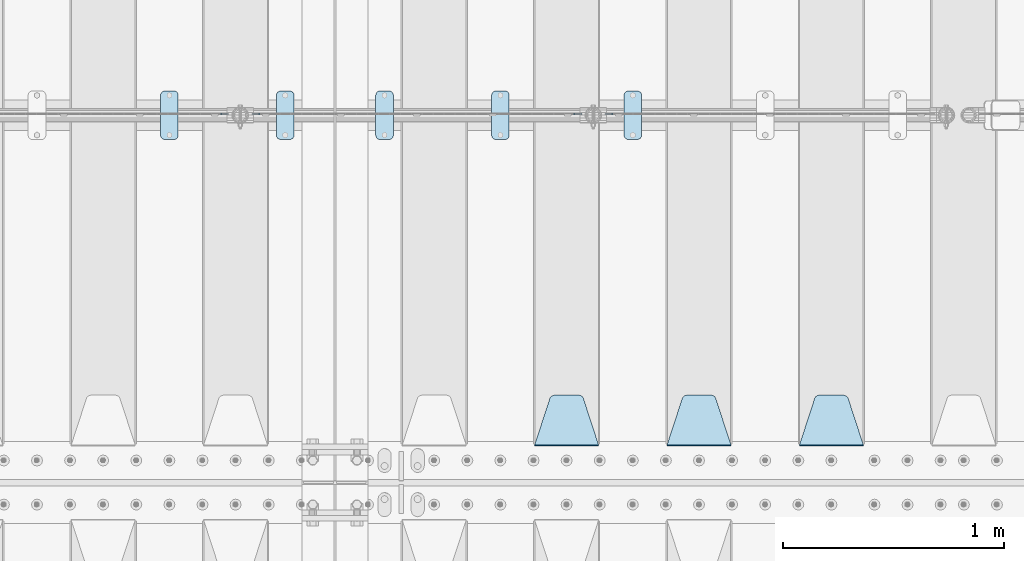
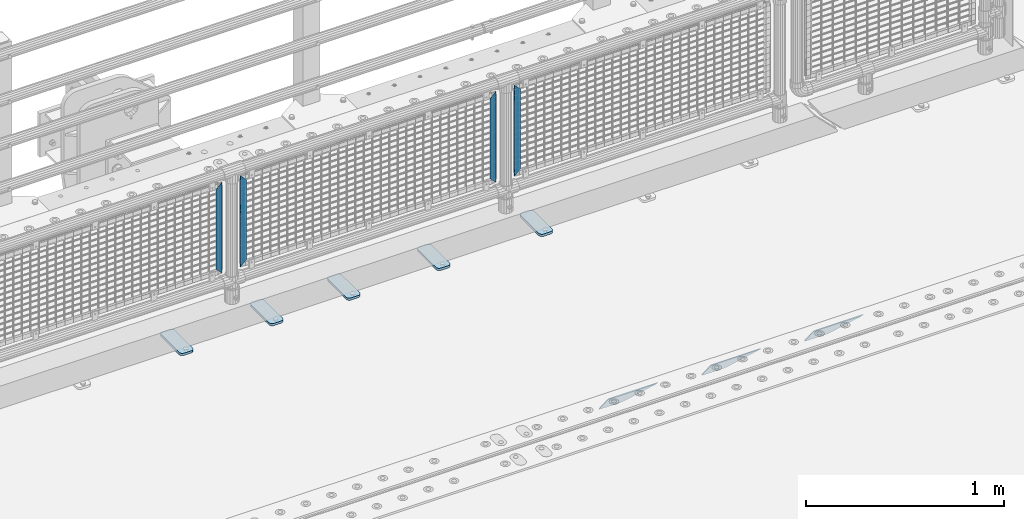
# One storey, part 228 of 257: 12 plates.
"""IFC2X3 building model written with IfcOpenShell, lengths in millimetres."""

from ifc_helpers import new_model, si_unit, frame, origin_with_axes, place, context, subcontext, project, spatial, faceted_brep, material, type_object, element, save


model = new_model("IFC2X3")

# Units and contexts
model_context = context("Model", 3, precision=1e-05, world=origin_with_axes())
body_context = subcontext(model_context, "Body", "Model", "MODEL_VIEW")
ifc_project = project(units=[si_unit("LENGTHUNIT", "METRE", prefix="MILLI"), si_unit("AREAUNIT", "SQUARE_METRE"), si_unit("VOLUMEUNIT", "CUBIC_METRE"), si_unit("MASSUNIT", "GRAM", prefix="KILO"), si_unit("TIMEUNIT", "SECOND"), si_unit("PLANEANGLEUNIT", "RADIAN"), si_unit("SOLIDANGLEUNIT", "STERADIAN"), si_unit("THERMODYNAMICTEMPERATUREUNIT", "DEGREE_CELSIUS"), si_unit("LUMINOUSINTENSITYUNIT", "LUMEN")], contexts=[model_context])

# Site, building, storey
site_placement = place(None, origin_with_axes())
site = spatial("IfcSite", under=ifc_project, at=site_placement, CompositionType="ELEMENT")
building_placement = place(site_placement, origin_with_axes())
building = spatial("IfcBuilding", under=site, at=building_placement, Name="Standard", CompositionType="ELEMENT")
storey_placement = place(building_placement, origin_with_axes())
storey = spatial("IfcBuildingStorey", under=building, at=storey_placement, Name="Undefined", CompositionType="ELEMENT", Elevation=0.0)

# Plates
ifc_material_1 = material(Name="STEEL/S355J2")
plate_type_1 = type_object("IfcPlateType", PredefinedType="NOTDEFINED")
plate_1_placement = place(storey_placement, frame((56010.0, 10774.5, 21.0199999999977), z_axis=(1.0, 0.0, 0.0), x_axis=(0.0, -1.0, 0.0)))
element("IfcPlate", 1, at=plate_1_placement, inside=storey, type_object=plate_type_1, material=ifc_material_1, context=body_context, shape_type="Brep", body=[
    faceted_brep([(0.0, -7.0, 20.0), (0.0, -7.0, 60.0), (0.0, 7.0, 60.0), (0.0, 7.0, 20.0), (0.384294391935327, -7.0, 63.9018064403208), (0.384294391935327, 7.0, 63.9018064403208), (1.52240934977453, -7.0, 67.6536686473046), (1.52240934977453, 7.0, 67.6536686473046), (3.37060775394821, -7.0, 71.1114046603907), (3.37060775394821, 7.0, 71.1114046603907), (5.85786437626848, -7.0, 74.1421356237333), (5.85786437626848, 7.0, 74.1421356237333), (8.88859533960749, -7.0, 76.6293922460536), (8.88859533960749, 7.0, 76.6293922460536), (12.3463313526991, -7.0, 78.4775906502255), (12.3463313526991, 7.0, 78.4775906502255), (16.0981935596774, -7.0, 79.6157056080629), (16.0981935596774, 7.0, 79.6157056080629), (20.0, -7.0, 80.0), (20.0, 7.0, 80.0), (200.0, -7.0, 80.0), (200.0, 7.0, 80.0), (203.901806440323, -7.0, 79.6157056080629), (203.901806440323, 7.0, 79.6157056080629), (207.653668647301, -7.0, 78.4775906502255), (207.653668647301, 7.0, 78.4775906502255), (211.111404660393, -7.0, 76.6293922460536), (211.111404660393, 7.0, 76.6293922460536), (214.142135623732, -7.0, 74.1421356237333), (214.142135623732, 7.0, 74.1421356237333), (216.629392246052, -7.0, 71.1114046603907), (216.629392246052, 7.0, 71.1114046603907), (218.477590650225, -7.0, 67.6536686473046), (218.477590650225, 7.0, 67.6536686473046), (219.615705608065, -7.0, 63.9018064403208), (219.615705608065, 7.0, 63.9018064403208), (220.0, -7.0, 60.0), (220.0, 7.0, 60.0), (220.0, -7.0, 20.0), (220.0, 7.0, 20.0), (219.615705608065, -7.0, 16.0981935596792), (219.615705608065, 7.0, 16.0981935596792), (218.477590650225, -7.0, 12.3463313526954), (218.477590650225, 7.0, 12.3463313526954), (216.629392246052, -7.0, 8.88859533960931), (216.629392246052, 7.0, 8.88859533960931), (214.142135623732, -7.0, 5.85786437626666), (214.142135623732, 7.0, 5.85786437626666), (211.111404660393, -7.0, 3.37060775394639), (211.111404660393, 7.0, 3.37060775394639), (207.653668647301, -7.0, 1.52240934977453), (207.653668647301, 7.0, 1.52240934977453), (203.901806440323, -7.0, 0.384294391937146), (203.901806440323, 7.0, 0.384294391937146), (200.0, -7.0, 0.0), (200.0, 7.0, 0.0), (20.0, -7.0, 0.0), (20.0, 7.0, 0.0), (16.0981935596774, -7.0, 0.384294391937146), (16.0981935596774, 7.0, 0.384294391937146), (12.3463313526991, -7.0, 1.52240934977453), (12.3463313526991, 7.0, 1.52240934977453), (8.88859533960749, -7.0, 3.37060775394639), (8.88859533960749, 7.0, 3.37060775394639), (5.85786437626848, -7.0, 5.85786437626666), (5.85786437626848, 7.0, 5.85786437626666), (3.37060775394821, -7.0, 8.88859533960931), (3.37060775394821, 7.0, 8.88859533960931), (1.52240934977453, -7.0, 12.3463313526954), (1.52240934977453, 7.0, 12.3463313526954), (0.384294391935327, -7.0, 16.0981935596792), (0.384294391935327, 7.0, 16.0981935596792)], [[[0, 1, 2, 3]], [[1, 4, 5, 2]], [[4, 6, 7, 5]], [[6, 8, 9, 7]], [[8, 10, 11, 9]], [[10, 12, 13, 11]], [[12, 14, 15, 13]], [[14, 16, 17, 15]], [[16, 18, 19, 17]], [[18, 20, 21, 19]], [[20, 22, 23, 21]], [[22, 24, 25, 23]], [[24, 26, 27, 25]], [[26, 28, 29, 27]], [[28, 30, 31, 29]], [[30, 32, 33, 31]], [[32, 34, 35, 33]], [[34, 36, 37, 35]], [[36, 38, 39, 37]], [[38, 40, 41, 39]], [[40, 42, 43, 41]], [[42, 44, 45, 43]], [[44, 46, 47, 45]], [[46, 48, 49, 47]], [[48, 50, 51, 49]], [[50, 52, 53, 51]], [[52, 54, 55, 53]], [[54, 56, 57, 55]], [[56, 58, 59, 57]], [[58, 60, 61, 59]], [[60, 62, 63, 61]], [[62, 64, 65, 63]], [[64, 66, 67, 65]], [[66, 68, 69, 67]], [[68, 70, 71, 69]], [[70, 0, 3, 71]], [[5, 7, 9, 11, 13, 15, 17, 19, 21, 23, 25, 27, 29, 31, 33, 35, 37, 39, 41, 43, 45, 47, 49, 51, 53, 55, 57, 59, 61, 63, 65, 67, 69, 71, 3, 2]], [[70, 68, 66, 64, 62, 60, 58, 56, 54, 52, 50, 48, 46, 44, 42, 40, 38, 36, 34, 32, 30, 28, 26, 24, 22, 20, 18, 16, 14, 12, 10, 8, 6, 4, 1, 0]]]),
])
plate_2_placement = place(storey_placement, frame((55410.0, 10774.5, 21.0199999999977), z_axis=(1.0, 0.0, 0.0), x_axis=(0.0, -1.0, 0.0)))
element("IfcPlate", 2, at=plate_2_placement, inside=storey, type_object=plate_type_1, material=ifc_material_1, context=body_context, shape_type="Brep", body=[
    faceted_brep([(0.0, -7.0, 20.0), (0.0, -7.0, 60.0), (0.0, 7.0, 60.0), (0.0, 7.0, 20.0), (0.384294391935327, -7.0, 63.9018064403208), (0.384294391935327, 7.0, 63.9018064403208), (1.52240934977453, -7.0, 67.6536686473046), (1.52240934977453, 7.0, 67.6536686473046), (3.37060775394821, -7.0, 71.1114046603907), (3.37060775394821, 7.0, 71.1114046603907), (5.85786437626848, -7.0, 74.1421356237333), (5.85786437626848, 7.0, 74.1421356237333), (8.88859533960749, -7.0, 76.6293922460536), (8.88859533960749, 7.0, 76.6293922460536), (12.3463313526991, -7.0, 78.4775906502255), (12.3463313526991, 7.0, 78.4775906502255), (16.0981935596774, -7.0, 79.6157056080629), (16.0981935596774, 7.0, 79.6157056080629), (20.0, -7.0, 80.0), (20.0, 7.0, 80.0), (200.0, -7.0, 80.0), (200.0, 7.0, 80.0), (203.901806440323, -7.0, 79.6157056080629), (203.901806440323, 7.0, 79.6157056080629), (207.653668647301, -7.0, 78.4775906502255), (207.653668647301, 7.0, 78.4775906502255), (211.111404660393, -7.0, 76.6293922460536), (211.111404660393, 7.0, 76.6293922460536), (214.142135623732, -7.0, 74.1421356237333), (214.142135623732, 7.0, 74.1421356237333), (216.629392246052, -7.0, 71.1114046603907), (216.629392246052, 7.0, 71.1114046603907), (218.477590650225, -7.0, 67.6536686473046), (218.477590650225, 7.0, 67.6536686473046), (219.615705608065, -7.0, 63.9018064403208), (219.615705608065, 7.0, 63.9018064403208), (220.0, -7.0, 60.0), (220.0, 7.0, 60.0), (220.0, -7.0, 20.0), (220.0, 7.0, 20.0), (219.615705608065, -7.0, 16.0981935596792), (219.615705608065, 7.0, 16.0981935596792), (218.477590650225, -7.0, 12.3463313526954), (218.477590650225, 7.0, 12.3463313526954), (216.629392246052, -7.0, 8.88859533960931), (216.629392246052, 7.0, 8.88859533960931), (214.142135623732, -7.0, 5.85786437626666), (214.142135623732, 7.0, 5.85786437626666), (211.111404660393, -7.0, 3.37060775394639), (211.111404660393, 7.0, 3.37060775394639), (207.653668647301, -7.0, 1.52240934977453), (207.653668647301, 7.0, 1.52240934977453), (203.901806440323, -7.0, 0.384294391937146), (203.901806440323, 7.0, 0.384294391937146), (200.0, -7.0, 0.0), (200.0, 7.0, 0.0), (20.0, -7.0, 0.0), (20.0, 7.0, 0.0), (16.0981935596774, -7.0, 0.384294391937146), (16.0981935596774, 7.0, 0.384294391937146), (12.3463313526991, -7.0, 1.52240934977453), (12.3463313526991, 7.0, 1.52240934977453), (8.88859533960749, -7.0, 3.37060775394639), (8.88859533960749, 7.0, 3.37060775394639), (5.85786437626848, -7.0, 5.85786437626666), (5.85786437626848, 7.0, 5.85786437626666), (3.37060775394821, -7.0, 8.88859533960931), (3.37060775394821, 7.0, 8.88859533960931), (1.52240934977453, -7.0, 12.3463313526954), (1.52240934977453, 7.0, 12.3463313526954), (0.384294391935327, -7.0, 16.0981935596792), (0.384294391935327, 7.0, 16.0981935596792)], [[[0, 1, 2, 3]], [[1, 4, 5, 2]], [[4, 6, 7, 5]], [[6, 8, 9, 7]], [[8, 10, 11, 9]], [[10, 12, 13, 11]], [[12, 14, 15, 13]], [[14, 16, 17, 15]], [[16, 18, 19, 17]], [[18, 20, 21, 19]], [[20, 22, 23, 21]], [[22, 24, 25, 23]], [[24, 26, 27, 25]], [[26, 28, 29, 27]], [[28, 30, 31, 29]], [[30, 32, 33, 31]], [[32, 34, 35, 33]], [[34, 36, 37, 35]], [[36, 38, 39, 37]], [[38, 40, 41, 39]], [[40, 42, 43, 41]], [[42, 44, 45, 43]], [[44, 46, 47, 45]], [[46, 48, 49, 47]], [[48, 50, 51, 49]], [[50, 52, 53, 51]], [[52, 54, 55, 53]], [[54, 56, 57, 55]], [[56, 58, 59, 57]], [[58, 60, 61, 59]], [[60, 62, 63, 61]], [[62, 64, 65, 63]], [[64, 66, 67, 65]], [[66, 68, 69, 67]], [[68, 70, 71, 69]], [[70, 0, 3, 71]], [[5, 7, 9, 11, 13, 15, 17, 19, 21, 23, 25, 27, 29, 31, 33, 35, 37, 39, 41, 43, 45, 47, 49, 51, 53, 55, 57, 59, 61, 63, 65, 67, 69, 71, 3, 2]], [[70, 68, 66, 64, 62, 60, 58, 56, 54, 52, 50, 48, 46, 44, 42, 40, 38, 36, 34, 32, 30, 28, 26, 24, 22, 20, 18, 16, 14, 12, 10, 8, 6, 4, 1, 0]]]),
])
plate_3_placement = place(storey_placement, frame((54435.0, 10774.5, 21.0199999999977), z_axis=(1.0, 0.0, 0.0), x_axis=(0.0, -1.0, 0.0)))
element("IfcPlate", 3, at=plate_3_placement, inside=storey, type_object=plate_type_1, material=ifc_material_1, context=body_context, shape_type="Brep", body=[
    faceted_brep([(0.0, -7.0, 20.0), (0.0, -7.0, 60.0), (0.0, 7.0, 60.0), (0.0, 7.0, 20.0), (0.384294391935327, -7.0, 63.9018064403208), (0.384294391935327, 7.0, 63.9018064403208), (1.52240934977453, -7.0, 67.6536686473046), (1.52240934977453, 7.0, 67.6536686473046), (3.37060775394821, -7.0, 71.1114046603907), (3.37060775394821, 7.0, 71.1114046603907), (5.85786437626848, -7.0, 74.1421356237333), (5.85786437626848, 7.0, 74.1421356237333), (8.88859533960749, -7.0, 76.6293922460536), (8.88859533960749, 7.0, 76.6293922460536), (12.3463313526991, -7.0, 78.4775906502255), (12.3463313526991, 7.0, 78.4775906502255), (16.0981935596774, -7.0, 79.6157056080629), (16.0981935596774, 7.0, 79.6157056080629), (20.0, -7.0, 80.0), (20.0, 7.0, 80.0), (200.0, -7.0, 80.0), (200.0, 7.0, 80.0), (203.901806440323, -7.0, 79.6157056080629), (203.901806440323, 7.0, 79.6157056080629), (207.653668647301, -7.0, 78.4775906502255), (207.653668647301, 7.0, 78.4775906502255), (211.111404660393, -7.0, 76.6293922460536), (211.111404660393, 7.0, 76.6293922460536), (214.142135623732, -7.0, 74.1421356237333), (214.142135623732, 7.0, 74.1421356237333), (216.629392246052, -7.0, 71.1114046603907), (216.629392246052, 7.0, 71.1114046603907), (218.477590650225, -7.0, 67.6536686473046), (218.477590650225, 7.0, 67.6536686473046), (219.615705608065, -7.0, 63.9018064403208), (219.615705608065, 7.0, 63.9018064403208), (220.0, -7.0, 60.0), (220.0, 7.0, 60.0), (220.0, -7.0, 20.0), (220.0, 7.0, 20.0), (219.615705608065, -7.0, 16.0981935596792), (219.615705608065, 7.0, 16.0981935596792), (218.477590650225, -7.0, 12.3463313526954), (218.477590650225, 7.0, 12.3463313526954), (216.629392246052, -7.0, 8.88859533960931), (216.629392246052, 7.0, 8.88859533960931), (214.142135623732, -7.0, 5.85786437626666), (214.142135623732, 7.0, 5.85786437626666), (211.111404660393, -7.0, 3.37060775394639), (211.111404660393, 7.0, 3.37060775394639), (207.653668647301, -7.0, 1.52240934977453), (207.653668647301, 7.0, 1.52240934977453), (203.901806440323, -7.0, 0.384294391937146), (203.901806440323, 7.0, 0.384294391937146), (200.0, -7.0, 0.0), (200.0, 7.0, 0.0), (20.0, -7.0, 0.0), (20.0, 7.0, 0.0), (16.0981935596774, -7.0, 0.384294391937146), (16.0981935596774, 7.0, 0.384294391937146), (12.3463313526991, -7.0, 1.52240934977453), (12.3463313526991, 7.0, 1.52240934977453), (8.88859533960749, -7.0, 3.37060775394639), (8.88859533960749, 7.0, 3.37060775394639), (5.85786437626848, -7.0, 5.85786437626666), (5.85786437626848, 7.0, 5.85786437626666), (3.37060775394821, -7.0, 8.88859533960931), (3.37060775394821, 7.0, 8.88859533960931), (1.52240934977453, -7.0, 12.3463313526954), (1.52240934977453, 7.0, 12.3463313526954), (0.384294391935327, -7.0, 16.0981935596792), (0.384294391935327, 7.0, 16.0981935596792)], [[[0, 1, 2, 3]], [[1, 4, 5, 2]], [[4, 6, 7, 5]], [[6, 8, 9, 7]], [[8, 10, 11, 9]], [[10, 12, 13, 11]], [[12, 14, 15, 13]], [[14, 16, 17, 15]], [[16, 18, 19, 17]], [[18, 20, 21, 19]], [[20, 22, 23, 21]], [[22, 24, 25, 23]], [[24, 26, 27, 25]], [[26, 28, 29, 27]], [[28, 30, 31, 29]], [[30, 32, 33, 31]], [[32, 34, 35, 33]], [[34, 36, 37, 35]], [[36, 38, 39, 37]], [[38, 40, 41, 39]], [[40, 42, 43, 41]], [[42, 44, 45, 43]], [[44, 46, 47, 45]], [[46, 48, 49, 47]], [[48, 50, 51, 49]], [[50, 52, 53, 51]], [[52, 54, 55, 53]], [[54, 56, 57, 55]], [[56, 58, 59, 57]], [[58, 60, 61, 59]], [[60, 62, 63, 61]], [[62, 64, 65, 63]], [[64, 66, 67, 65]], [[66, 68, 69, 67]], [[68, 70, 71, 69]], [[70, 0, 3, 71]], [[5, 7, 9, 11, 13, 15, 17, 19, 21, 23, 25, 27, 29, 31, 33, 35, 37, 39, 41, 43, 45, 47, 49, 51, 53, 55, 57, 59, 61, 63, 65, 67, 69, 71, 3, 2]], [[70, 68, 66, 64, 62, 60, 58, 56, 54, 52, 50, 48, 46, 44, 42, 40, 38, 36, 34, 32, 30, 28, 26, 24, 22, 20, 18, 16, 14, 12, 10, 8, 6, 4, 1, 0]]]),
])
plate_4_placement = place(storey_placement, frame((53910.0, 10774.5, 21.0199999999977), z_axis=(1.0, 0.0, 0.0), x_axis=(0.0, -1.0, 0.0)))
element("IfcPlate", 4, at=plate_4_placement, inside=storey, type_object=plate_type_1, material=ifc_material_1, context=body_context, shape_type="Brep", body=[
    faceted_brep([(0.0, -7.0, 20.0), (0.0, -7.0, 60.0), (0.0, 7.0, 60.0), (0.0, 7.0, 20.0), (0.384294391935327, -7.0, 63.9018064403208), (0.384294391935327, 7.0, 63.9018064403208), (1.52240934977453, -7.0, 67.6536686473046), (1.52240934977453, 7.0, 67.6536686473046), (3.37060775394821, -7.0, 71.1114046603907), (3.37060775394821, 7.0, 71.1114046603907), (5.85786437626848, -7.0, 74.1421356237333), (5.85786437626848, 7.0, 74.1421356237333), (8.88859533960749, -7.0, 76.6293922460536), (8.88859533960749, 7.0, 76.6293922460536), (12.3463313526991, -7.0, 78.4775906502255), (12.3463313526991, 7.0, 78.4775906502255), (16.0981935596774, -7.0, 79.6157056080629), (16.0981935596774, 7.0, 79.6157056080629), (20.0, -7.0, 80.0), (20.0, 7.0, 80.0), (200.0, -7.0, 80.0), (200.0, 7.0, 80.0), (203.901806440323, -7.0, 79.6157056080629), (203.901806440323, 7.0, 79.6157056080629), (207.653668647301, -7.0, 78.4775906502255), (207.653668647301, 7.0, 78.4775906502255), (211.111404660393, -7.0, 76.6293922460536), (211.111404660393, 7.0, 76.6293922460536), (214.142135623732, -7.0, 74.1421356237333), (214.142135623732, 7.0, 74.1421356237333), (216.629392246052, -7.0, 71.1114046603907), (216.629392246052, 7.0, 71.1114046603907), (218.477590650225, -7.0, 67.6536686473046), (218.477590650225, 7.0, 67.6536686473046), (219.615705608065, -7.0, 63.9018064403208), (219.615705608065, 7.0, 63.9018064403208), (220.0, -7.0, 60.0), (220.0, 7.0, 60.0), (220.0, -7.0, 20.0), (220.0, 7.0, 20.0), (219.615705608065, -7.0, 16.0981935596792), (219.615705608065, 7.0, 16.0981935596792), (218.477590650225, -7.0, 12.3463313526954), (218.477590650225, 7.0, 12.3463313526954), (216.629392246052, -7.0, 8.88859533960931), (216.629392246052, 7.0, 8.88859533960931), (214.142135623732, -7.0, 5.85786437626666), (214.142135623732, 7.0, 5.85786437626666), (211.111404660393, -7.0, 3.37060775394639), (211.111404660393, 7.0, 3.37060775394639), (207.653668647301, -7.0, 1.52240934977453), (207.653668647301, 7.0, 1.52240934977453), (203.901806440323, -7.0, 0.384294391937146), (203.901806440323, 7.0, 0.384294391937146), (200.0, -7.0, 0.0), (200.0, 7.0, 0.0), (20.0, -7.0, 0.0), (20.0, 7.0, 0.0), (16.0981935596774, -7.0, 0.384294391937146), (16.0981935596774, 7.0, 0.384294391937146), (12.3463313526991, -7.0, 1.52240934977453), (12.3463313526991, 7.0, 1.52240934977453), (8.88859533960749, -7.0, 3.37060775394639), (8.88859533960749, 7.0, 3.37060775394639), (5.85786437626848, -7.0, 5.85786437626666), (5.85786437626848, 7.0, 5.85786437626666), (3.37060775394821, -7.0, 8.88859533960931), (3.37060775394821, 7.0, 8.88859533960931), (1.52240934977453, -7.0, 12.3463313526954), (1.52240934977453, 7.0, 12.3463313526954), (0.384294391935327, -7.0, 16.0981935596792), (0.384294391935327, 7.0, 16.0981935596792)], [[[0, 1, 2, 3]], [[1, 4, 5, 2]], [[4, 6, 7, 5]], [[6, 8, 9, 7]], [[8, 10, 11, 9]], [[10, 12, 13, 11]], [[12, 14, 15, 13]], [[14, 16, 17, 15]], [[16, 18, 19, 17]], [[18, 20, 21, 19]], [[20, 22, 23, 21]], [[22, 24, 25, 23]], [[24, 26, 27, 25]], [[26, 28, 29, 27]], [[28, 30, 31, 29]], [[30, 32, 33, 31]], [[32, 34, 35, 33]], [[34, 36, 37, 35]], [[36, 38, 39, 37]], [[38, 40, 41, 39]], [[40, 42, 43, 41]], [[42, 44, 45, 43]], [[44, 46, 47, 45]], [[46, 48, 49, 47]], [[48, 50, 51, 49]], [[50, 52, 53, 51]], [[52, 54, 55, 53]], [[54, 56, 57, 55]], [[56, 58, 59, 57]], [[58, 60, 61, 59]], [[60, 62, 63, 61]], [[62, 64, 65, 63]], [[64, 66, 67, 65]], [[66, 68, 69, 67]], [[68, 70, 71, 69]], [[70, 0, 3, 71]], [[5, 7, 9, 11, 13, 15, 17, 19, 21, 23, 25, 27, 29, 31, 33, 35, 37, 39, 41, 43, 45, 47, 49, 51, 53, 55, 57, 59, 61, 63, 65, 67, 69, 71, 3, 2]], [[70, 68, 66, 64, 62, 60, 58, 56, 54, 52, 50, 48, 46, 44, 42, 40, 38, 36, 34, 32, 30, 28, 26, 24, 22, 20, 18, 16, 14, 12, 10, 8, 6, 4, 1, 0]]]),
])
plate_5_placement = place(storey_placement, frame((54885.0, 10774.5, 21.0199999999977), z_axis=(1.0, 0.0, 0.0), x_axis=(0.0, -1.0, 0.0)))
element("IfcPlate", 5, at=plate_5_placement, inside=storey, type_object=plate_type_1, material=ifc_material_1, context=body_context, shape_type="Brep", body=[
    faceted_brep([(0.0, -7.0, 20.0), (0.0, -7.0, 60.0), (0.0, 7.0, 60.0), (0.0, 7.0, 20.0), (0.384294391935327, -7.0, 63.9018064403208), (0.384294391935327, 7.0, 63.9018064403208), (1.52240934977453, -7.0, 67.6536686473046), (1.52240934977453, 7.0, 67.6536686473046), (3.37060775394821, -7.0, 71.1114046603907), (3.37060775394821, 7.0, 71.1114046603907), (5.85786437626848, -7.0, 74.1421356237333), (5.85786437626848, 7.0, 74.1421356237333), (8.88859533960749, -7.0, 76.6293922460536), (8.88859533960749, 7.0, 76.6293922460536), (12.3463313526991, -7.0, 78.4775906502255), (12.3463313526991, 7.0, 78.4775906502255), (16.0981935596774, -7.0, 79.6157056080629), (16.0981935596774, 7.0, 79.6157056080629), (20.0, -7.0, 80.0), (20.0, 7.0, 80.0), (200.0, -7.0, 80.0), (200.0, 7.0, 80.0), (203.901806440323, -7.0, 79.6157056080629), (203.901806440323, 7.0, 79.6157056080629), (207.653668647301, -7.0, 78.4775906502255), (207.653668647301, 7.0, 78.4775906502255), (211.111404660393, -7.0, 76.6293922460536), (211.111404660393, 7.0, 76.6293922460536), (214.142135623732, -7.0, 74.1421356237333), (214.142135623732, 7.0, 74.1421356237333), (216.629392246052, -7.0, 71.1114046603907), (216.629392246052, 7.0, 71.1114046603907), (218.477590650225, -7.0, 67.6536686473046), (218.477590650225, 7.0, 67.6536686473046), (219.615705608065, -7.0, 63.9018064403208), (219.615705608065, 7.0, 63.9018064403208), (220.0, -7.0, 60.0), (220.0, 7.0, 60.0), (220.0, -7.0, 20.0), (220.0, 7.0, 20.0), (219.615705608065, -7.0, 16.0981935596792), (219.615705608065, 7.0, 16.0981935596792), (218.477590650225, -7.0, 12.3463313526954), (218.477590650225, 7.0, 12.3463313526954), (216.629392246052, -7.0, 8.88859533960931), (216.629392246052, 7.0, 8.88859533960931), (214.142135623732, -7.0, 5.85786437626666), (214.142135623732, 7.0, 5.85786437626666), (211.111404660393, -7.0, 3.37060775394639), (211.111404660393, 7.0, 3.37060775394639), (207.653668647301, -7.0, 1.52240934977453), (207.653668647301, 7.0, 1.52240934977453), (203.901806440323, -7.0, 0.384294391937146), (203.901806440323, 7.0, 0.384294391937146), (200.0, -7.0, 0.0), (200.0, 7.0, 0.0), (20.0, -7.0, 0.0), (20.0, 7.0, 0.0), (16.0981935596774, -7.0, 0.384294391937146), (16.0981935596774, 7.0, 0.384294391937146), (12.3463313526991, -7.0, 1.52240934977453), (12.3463313526991, 7.0, 1.52240934977453), (8.88859533960749, -7.0, 3.37060775394639), (8.88859533960749, 7.0, 3.37060775394639), (5.85786437626848, -7.0, 5.85786437626666), (5.85786437626848, 7.0, 5.85786437626666), (3.37060775394821, -7.0, 8.88859533960931), (3.37060775394821, 7.0, 8.88859533960931), (1.52240934977453, -7.0, 12.3463313526954), (1.52240934977453, 7.0, 12.3463313526954), (0.384294391935327, -7.0, 16.0981935596792), (0.384294391935327, 7.0, 16.0981935596792)], [[[0, 1, 2, 3]], [[1, 4, 5, 2]], [[4, 6, 7, 5]], [[6, 8, 9, 7]], [[8, 10, 11, 9]], [[10, 12, 13, 11]], [[12, 14, 15, 13]], [[14, 16, 17, 15]], [[16, 18, 19, 17]], [[18, 20, 21, 19]], [[20, 22, 23, 21]], [[22, 24, 25, 23]], [[24, 26, 27, 25]], [[26, 28, 29, 27]], [[28, 30, 31, 29]], [[30, 32, 33, 31]], [[32, 34, 35, 33]], [[34, 36, 37, 35]], [[36, 38, 39, 37]], [[38, 40, 41, 39]], [[40, 42, 43, 41]], [[42, 44, 45, 43]], [[44, 46, 47, 45]], [[46, 48, 49, 47]], [[48, 50, 51, 49]], [[50, 52, 53, 51]], [[52, 54, 55, 53]], [[54, 56, 57, 55]], [[56, 58, 59, 57]], [[58, 60, 61, 59]], [[60, 62, 63, 61]], [[62, 64, 65, 63]], [[64, 66, 67, 65]], [[66, 68, 69, 67]], [[68, 70, 71, 69]], [[70, 0, 3, 71]], [[5, 7, 9, 11, 13, 15, 17, 19, 21, 23, 25, 27, 29, 31, 33, 35, 37, 39, 41, 43, 45, 47, 49, 51, 53, 55, 57, 59, 61, 63, 65, 67, 69, 71, 3, 2]], [[70, 68, 66, 64, 62, 60, 58, 56, 54, 52, 50, 48, 46, 44, 42, 40, 38, 36, 34, 32, 30, 28, 26, 24, 22, 20, 18, 16, 14, 12, 10, 8, 6, 4, 1, 0]]]),
])
ifc_material_2 = material(Name="STEEL/S355N")
plate_type_2 = type_object("IfcPlateType", PredefinedType="NOTDEFINED")
plate_6_placement = place(storey_placement, frame((57095.0, 9168.23223304703, -1.76776695296758), z_axis=(0.0, 0.707106781186547, -0.707106781186548), x_axis=(-1.0, 0.0, 0.0)))
element("IfcPlate", 6, at=plate_6_placement, inside=storey, type_object=plate_type_2, material=ifc_material_2, context=body_context, shape_type="Brep", body=[
    faceted_brep([(0.0, -2.5, 0.0), (69.345504679477, -2.50000000000091, 300.17173142483), (69.345504679477, 2.5, 300.171731424831), (0.0, 2.5, 0.0), (70.927406119954, -2.50000000000091, 304.8974424154), (70.927406119954, 2.5, 304.8974424154), (73.3818627772271, -2.50000000000091, 309.234538108527), (73.3818627772271, 2.49999999999909, 309.234538108527), (76.6187032999587, -2.5, 313.023683126103), (76.6187032999587, 2.5, 313.023683126103), (80.5190132705029, -2.5, 316.125672595372), (80.5190132705029, 2.5, 316.125672595371), (84.9395038596849, -2.5, 318.426546230476), (84.9395038596849, 2.5, 318.426546230477), (89.7177759439219, -2.5, 319.841774983275), (89.7177759439219, 2.5, 319.841774983275), (94.6782862926484, -2.5, 320.319366455079), (94.6782862926484, 2.5, 320.319366455079), (195.321713707352, -2.5, 320.319366455079), (195.321713707352, 2.5, 320.319366455079), (200.282224056078, -2.5, 319.841774983275), (200.282224056078, 2.49999999999909, 319.841774983275), (205.060496140315, -2.5, 318.426546230476), (205.060496140315, 2.49999999999909, 318.426546230475), (209.480986729497, -2.5, 316.125672595371), (209.480986729497, 2.5, 316.125672595371), (213.381296700041, -2.50000000000091, 313.023683126102), (213.381296700041, 2.5, 313.023683126103), (216.618137222766, -2.50000000000091, 309.234538108527), (216.618137222766, 2.5, 309.234538108527), (219.072593880039, -2.5, 304.897442415399), (219.072593880039, 2.5, 304.897442415399), (220.654495320523, -2.50000000000091, 300.17173142483), (220.654495320523, 2.5, 300.171731424831), (290.0, -2.50000000000091, 0.0), (290.0, 2.5, 9.09494701772928e-13)], [[[0, 1, 2, 3]], [[1, 4, 5, 2]], [[4, 6, 7, 5]], [[6, 8, 9, 7]], [[8, 10, 11, 9]], [[10, 12, 13, 11]], [[12, 14, 15, 13]], [[14, 16, 17, 15]], [[16, 18, 19, 17]], [[18, 20, 21, 19]], [[20, 22, 23, 21]], [[22, 24, 25, 23]], [[24, 26, 27, 25]], [[26, 28, 29, 27]], [[28, 30, 31, 29]], [[30, 32, 33, 31]], [[32, 34, 35, 33]], [[34, 0, 3, 35]], [[5, 7, 9, 11, 13, 15, 17, 19, 21, 23, 25, 27, 29, 31, 33, 35, 3, 2]], [[34, 32, 30, 28, 26, 24, 22, 20, 18, 16, 14, 12, 10, 8, 6, 4, 1, 0]]]),
])
plate_7_placement = place(storey_placement, frame((56495.0, 9168.23223304703, -1.76776695296758), z_axis=(0.0, 0.707106781186547, -0.707106781186548), x_axis=(-1.0, 0.0, 0.0)))
element("IfcPlate", 7, at=plate_7_placement, inside=storey, type_object=plate_type_2, material=ifc_material_2, context=body_context, shape_type="Brep", body=[
    faceted_brep([(0.0, -2.5, 0.0), (69.345504679477, -2.50000000000091, 300.17173142483), (69.345504679477, 2.5, 300.171731424831), (0.0, 2.5, 0.0), (70.927406119954, -2.50000000000091, 304.8974424154), (70.927406119954, 2.5, 304.8974424154), (73.3818627772271, -2.50000000000091, 309.234538108527), (73.3818627772271, 2.49999999999909, 309.234538108527), (76.6187032999587, -2.5, 313.023683126103), (76.6187032999587, 2.5, 313.023683126103), (80.5190132705029, -2.5, 316.125672595372), (80.5190132705029, 2.5, 316.125672595371), (84.9395038596849, -2.5, 318.426546230476), (84.9395038596849, 2.5, 318.426546230477), (89.7177759439219, -2.5, 319.841774983275), (89.7177759439219, 2.5, 319.841774983275), (94.6782862926484, -2.5, 320.319366455079), (94.6782862926484, 2.5, 320.319366455079), (195.321713707352, -2.5, 320.319366455079), (195.321713707352, 2.5, 320.319366455079), (200.282224056078, -2.5, 319.841774983275), (200.282224056078, 2.49999999999909, 319.841774983275), (205.060496140315, -2.5, 318.426546230476), (205.060496140315, 2.49999999999909, 318.426546230475), (209.480986729497, -2.5, 316.125672595371), (209.480986729497, 2.5, 316.125672595371), (213.381296700041, -2.50000000000091, 313.023683126102), (213.381296700041, 2.5, 313.023683126103), (216.618137222766, -2.50000000000091, 309.234538108527), (216.618137222766, 2.5, 309.234538108527), (219.072593880039, -2.5, 304.897442415399), (219.072593880039, 2.5, 304.897442415399), (220.654495320523, -2.50000000000091, 300.17173142483), (220.654495320523, 2.5, 300.171731424831), (290.0, -2.50000000000091, 0.0), (290.0, 2.5, 9.09494701772928e-13)], [[[0, 1, 2, 3]], [[1, 4, 5, 2]], [[4, 6, 7, 5]], [[6, 8, 9, 7]], [[8, 10, 11, 9]], [[10, 12, 13, 11]], [[12, 14, 15, 13]], [[14, 16, 17, 15]], [[16, 18, 19, 17]], [[18, 20, 21, 19]], [[20, 22, 23, 21]], [[22, 24, 25, 23]], [[24, 26, 27, 25]], [[26, 28, 29, 27]], [[28, 30, 31, 29]], [[30, 32, 33, 31]], [[32, 34, 35, 33]], [[34, 0, 3, 35]], [[5, 7, 9, 11, 13, 15, 17, 19, 21, 23, 25, 27, 29, 31, 33, 35, 3, 2]], [[34, 32, 30, 28, 26, 24, 22, 20, 18, 16, 14, 12, 10, 8, 6, 4, 1, 0]]]),
])
plate_8_placement = place(storey_placement, frame((55895.0, 9168.23223304703, -1.76776695296758), z_axis=(0.0, 0.707106781186547, -0.707106781186548), x_axis=(-1.0, 0.0, 0.0)))
element("IfcPlate", 8, at=plate_8_placement, inside=storey, type_object=plate_type_2, material=ifc_material_2, context=body_context, shape_type="Brep", body=[
    faceted_brep([(0.0, -2.5, 0.0), (69.345504679477, -2.50000000000091, 300.17173142483), (69.345504679477, 2.5, 300.171731424831), (0.0, 2.5, 0.0), (70.927406119954, -2.50000000000091, 304.8974424154), (70.927406119954, 2.5, 304.8974424154), (73.3818627772271, -2.50000000000091, 309.234538108527), (73.3818627772271, 2.49999999999909, 309.234538108527), (76.6187032999587, -2.5, 313.023683126103), (76.6187032999587, 2.5, 313.023683126103), (80.5190132705029, -2.5, 316.125672595372), (80.5190132705029, 2.5, 316.125672595371), (84.9395038596849, -2.5, 318.426546230476), (84.9395038596849, 2.5, 318.426546230477), (89.7177759439219, -2.5, 319.841774983275), (89.7177759439219, 2.5, 319.841774983275), (94.6782862926484, -2.5, 320.319366455079), (94.6782862926484, 2.5, 320.319366455079), (195.321713707352, -2.5, 320.319366455079), (195.321713707352, 2.5, 320.319366455079), (200.282224056078, -2.5, 319.841774983275), (200.282224056078, 2.49999999999909, 319.841774983275), (205.060496140315, -2.5, 318.426546230476), (205.060496140315, 2.49999999999909, 318.426546230475), (209.480986729497, -2.5, 316.125672595371), (209.480986729497, 2.5, 316.125672595371), (213.381296700041, -2.50000000000091, 313.023683126102), (213.381296700041, 2.5, 313.023683126103), (216.618137222766, -2.50000000000091, 309.234538108527), (216.618137222766, 2.5, 309.234538108527), (219.072593880039, -2.5, 304.897442415399), (219.072593880039, 2.5, 304.897442415399), (220.654495320523, -2.50000000000091, 300.17173142483), (220.654495320523, 2.5, 300.171731424831), (290.0, -2.50000000000091, 0.0), (290.0, 2.5, 9.09494701772928e-13)], [[[0, 1, 2, 3]], [[1, 4, 5, 2]], [[4, 6, 7, 5]], [[6, 8, 9, 7]], [[8, 10, 11, 9]], [[10, 12, 13, 11]], [[12, 14, 15, 13]], [[14, 16, 17, 15]], [[16, 18, 19, 17]], [[18, 20, 21, 19]], [[20, 22, 23, 21]], [[22, 24, 25, 23]], [[24, 26, 27, 25]], [[26, 28, 29, 27]], [[28, 30, 31, 29]], [[30, 32, 33, 31]], [[32, 34, 35, 33]], [[34, 0, 3, 35]], [[5, 7, 9, 11, 13, 15, 17, 19, 21, 23, 25, 27, 29, 31, 33, 35, 3, 2]], [[34, 32, 30, 28, 26, 24, 22, 20, 18, 16, 14, 12, 10, 8, 6, 4, 1, 0]]]),
])
ifc_material_3 = material(Name="Misc_Undefined")
plate_type_3 = type_object("IfcPlateType", PredefinedType="NOTDEFINED")
for number, where, z_axis, x_axis in (
    (9, (55959.509713541, 10670.5, 879.519963133601), (-0.707008801899317, 0.0, -0.707204746899292), (-0.707204746899293, 0.0, 0.707008801899317)),
    (10, (54359.509713541, 10670.5, 879.519963133601), (-0.707008801899317, 0.0, -0.707204746899292), (-0.707204746899293, 0.0, 0.707008801899317)),
):
    element("IfcPlate", number, at=place(storey_placement, frame(where, z_axis=z_axis, x_axis=x_axis)), inside=storey, type_object=plate_type_3, material=ifc_material_3, context=body_context, shape_type="Brep", body=[
        faceted_brep([(0.0, -1.5, -5.6843418860808e-14), (-348.552185058586, -1.5, 348.655029296868), (-348.552185058586, 1.5, 348.655029296868), (0.0, 1.5, -5.6843418860808e-14), (-348.544891357407, -1.5, 398.152496337891), (-348.544891357407, 1.5, 398.152496337891), (49.5043945312573, -1.5, 7.27595761418343e-11), (49.5043945312573, 1.5, 7.27595761418343e-11)], [[[0, 1, 2, 3]], [[1, 4, 5, 2]], [[4, 6, 7, 5]], [[6, 0, 3, 7]], [[5, 7, 3, 2]], [[6, 4, 1, 0]]]),
    ])
for number, where, z_axis, x_axis in (
    (11, (55782.4996874836, 10670.5, 879.52), (0.707103624179501, 0.0, -0.707109938179499), (0.707109938179525, 0.0, 0.707103624179475)),
    (12, (54182.4996874836, 10670.5, 879.52), (0.707103624179501, 0.0, -0.707109938179499), (0.707109938179525, 0.0, 0.707103624179475)),
):
    element("IfcPlate", number, at=place(storey_placement, frame(where, z_axis=z_axis, x_axis=x_axis)), inside=storey, type_object=plate_type_3, material=ifc_material_3, context=body_context, shape_type="Brep", body=[
        faceted_brep([(0.0, -1.5, -5.6843418860808e-14), (-348.605163574226, -1.5, 348.602081298828), (-348.605163574226, 1.5, 348.602081298828), (0.0, 1.5, -5.6843418860808e-14), (-348.605163574226, -1.5, 398.099334716804), (-348.605163574226, 1.5, 398.099334716804), (49.4976959228443, -1.5, 6.54836185276508e-11), (49.4976959228443, 1.5, 6.54836185276508e-11)], [[[0, 1, 2, 3]], [[1, 4, 5, 2]], [[4, 6, 7, 5]], [[6, 0, 3, 7]], [[5, 7, 3, 2]], [[6, 4, 1, 0]]]),
    ])

save(model, "model.ifc")
